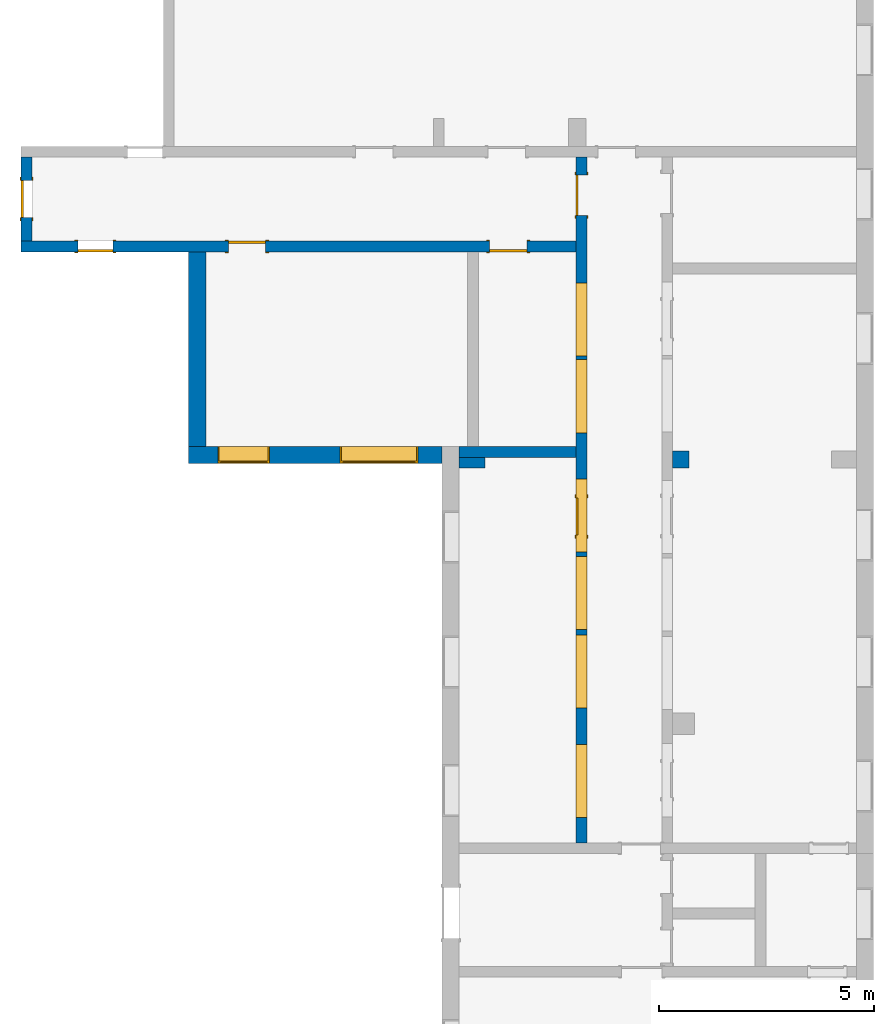
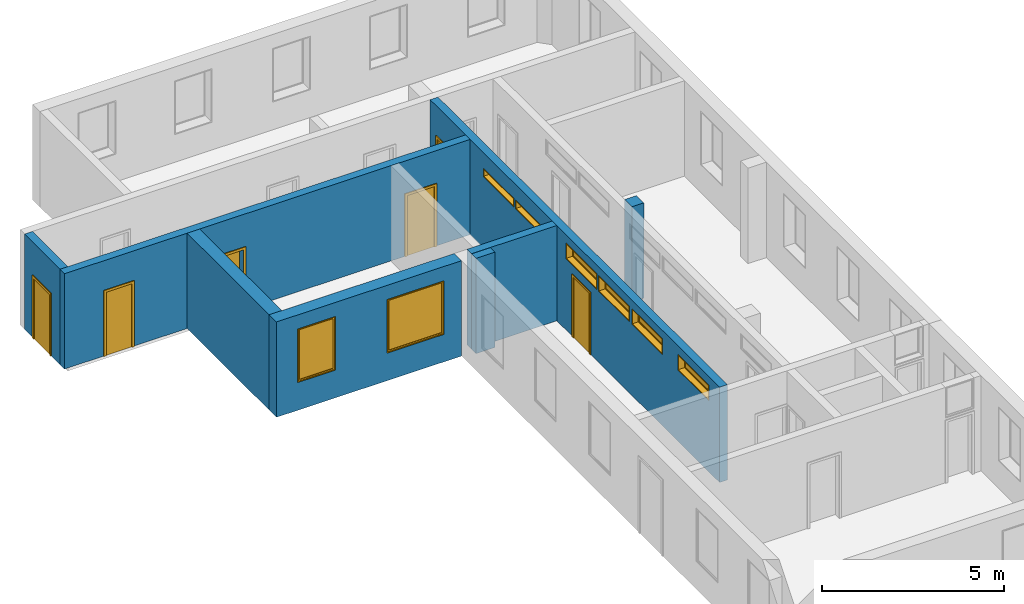
"""IFC2X3 building model written with IfcOpenShell, lengths in millimetres."""

from ifc_helpers import new_model, entity, si_unit, converted_unit, derived_unit, direction, frame, frame_2d, origin, origin_2d_with_axis, place, context, subcontext, project, spatial, polyline, rectangle, outline, extrude, source, transform, mapped, material, material_list, layer, layer_set, layer_usage, type_object, type_shapes, element, fill, save


model = new_model("IFC2X3")

# Units and contexts
model_context = context("Model", 3, precision=0.01, world=origin(), true_north=direction((6.12303176911189e-17, 1.0)))
context_of_model = context(None, 3, precision=0.01, world=origin(), true_north=direction((6.12303176911189e-17, 1.0)))
body_context = subcontext(model_context, "Body", "Model", "MODEL_VIEW")
ifc_project = project(units=[si_unit("LENGTHUNIT", "METRE", prefix="MILLI"), si_unit("AREAUNIT", "SQUARE_METRE"), si_unit("VOLUMEUNIT", "CUBIC_METRE"), converted_unit("PLANEANGLEUNIT", "DEGREE", entity("IfcRatioMeasure", 0.0174532925199433), si_unit("PLANEANGLEUNIT", "RADIAN"), dimensions=[0, 0, 0, 0, 0, 0, 0]), si_unit("MASSUNIT", "GRAM", prefix="KILO"), si_unit("TIMEUNIT", "SECOND"), si_unit("FREQUENCYUNIT", "HERTZ"), si_unit("THERMODYNAMICTEMPERATUREUNIT", "DEGREE_CELSIUS"), derived_unit("THERMALTRANSMITTANCEUNIT", [(si_unit("MASSUNIT", "GRAM", prefix="KILO"), 1), (si_unit("THERMODYNAMICTEMPERATUREUNIT", "KELVIN"), -1), (si_unit("TIMEUNIT", "SECOND"), -3)]), derived_unit("VOLUMETRICFLOWRATEUNIT", [(si_unit("LENGTHUNIT", "METRE"), 3), (si_unit("TIMEUNIT", "SECOND"), -1)]), si_unit("ELECTRICCURRENTUNIT", "AMPERE"), si_unit("ELECTRICVOLTAGEUNIT", "VOLT"), si_unit("POWERUNIT", "WATT"), si_unit("FORCEUNIT", "NEWTON", prefix="KILO"), si_unit("ILLUMINANCEUNIT", "LUX"), si_unit("LUMINOUSFLUXUNIT", "LUMEN"), si_unit("LUMINOUSINTENSITYUNIT", "CANDELA"), si_unit("PRESSUREUNIT", "PASCAL")], contexts=[model_context, context_of_model])

# Site, building, storey
site_placement = place(None, origin())
site = spatial("IfcSite", under=ifc_project, at=site_placement, CompositionType="ELEMENT")
building_placement = place(site_placement, origin())
building = spatial("IfcBuilding", under=site, at=building_placement, CompositionType="ELEMENT")
storey_1_placement = place(building_placement, origin())
storey_1 = spatial("IfcBuildingStorey", under=building, at=storey_1_placement, Name="i Plan", CompositionType="ELEMENT", Elevation=-5.41433564649196e-13)

# Wall, openings
ifc_material_1 = material(Name="Brick, Common")
ifc_layer_1 = layer(ifc_material_1, 400.0)
ifc_layer_set_1 = layer_set([ifc_layer_1], Name="Basic Wall:400mm")
ifc_layer_usage_1 = layer_usage(ifc_layer_set_1, "AXIS2", "NEGATIVE", 200.0)
wall_type_1 = type_object("IfcWallType", Name="Basic Wall:400mm", PredefinedType="STANDARD", material=ifc_layer_set_1)
wall_1_placement = place(storey_1_placement, frame((-4511.58809277855, 2433.01583504001, 0.0), z_axis=(0.0, 0.0, 1.0), x_axis=(-1.0, 0.0, 0.0)))
wall_1 = element("IfcWallStandardCase", 1, at=wall_1_placement, inside=storey_1, type_object=wall_type_1, material=ifc_layer_usage_1, Name="Basic Wall:400mm", ObjectType="Basic Wall:400mm", context=body_context, shape_type="SweptSolid", body=[
    extrude(rectangle(XDim=5876.63670242216, YDim=400.0, at=frame_2d((2938.31835121108, 2.8421709430404e-14), x_axis=(-1.0, 0.0))), origin(), (0.0, 0.0, 1.0), 3199.99999999984),
])
opening_1_placement = place(wall_1_placement, frame((4001.63670242216, -200.0, 930.0)))
opening_1 = element("IfcOpeningElement", 2, at=opening_1_placement, cuts=wall_1, Name="M_Fixed:72_1", ObjectType="Opening", context=body_context, shape_type="SweptSolid", body=[
    extrude(rectangle(XDim=1800.0, YDim=1200.0, at=frame_2d((899.999999999998, 600.000000000001), x_axis=(1.0, 0.0))), frame((0.0, 0.0, 0.0), z_axis=(0.0, 1.0, 0.0), x_axis=(0.0, 0.0, 1.0)), (0.0, 0.0, 1.0), 400.0),
])
opening_2_placement = place(wall_1_placement, frame((561.636702422159, -200.0, 922.685489525412)))
opening_2 = element("IfcOpeningElement", 3, at=opening_2_placement, cuts=wall_1, Name="M_Fixed:72_2 extra long:1", ObjectType="Opening", context=body_context, shape_type="SweptSolid", body=[
    extrude(rectangle(XDim=1800.0, YDim=1800.0, at=frame_2d((899.999999999998, 900.0), x_axis=(1.0, 0.0))), frame((0.0, 0.0, 0.0), z_axis=(0.0, 1.0, 0.0), x_axis=(0.0, 0.0, 1.0)), (0.0, 0.0, 1.0), 400.0),
])

# Storey
storey_2_placement = place(building_placement, frame((0.0, 0.0, 960.0)))
storey_2 = spatial("IfcBuildingStorey", under=building, at=storey_2_placement, Name="Bottom windows", CompositionType="ELEMENT", Elevation=959.999999999999)

# Window
ifc_material_2 = material(Name="Glass")
ifc_material_3 = material(Name="Sash")
ifc_material_list_1 = material_list([ifc_material_2, ifc_material_3])
ifc_material_list_2 = material_list([ifc_material_2, ifc_material_3])
window_style_1 = type_object("IfcWindowStyle", Name="72", ConstructionType="NOTDEFINED", OperationType="NOTDEFINED", ParameterTakesPrecedence=False, Sizeable=False, material=ifc_material_list_2)
shared_shape_1 = source(origin(), body_context, "Body", "SweptSolid", [
    extrude(rectangle(XDim=12.0, YDim=1074.0, at=origin_2d_with_axis()), frame((600.0, 359.0, 63.0), z_axis=(0.0, 0.0, 1.0), x_axis=(0.0, -1.0, 0.0)), (0.0, 0.0, 1.0), 1674.0),
    extrude(outline(polyline([(-581.0, -881.0), (581.0, -881.0), (581.0, 881.0), (-581.0, 881.0), (-581.0, -881.0)]), holes=[polyline([(-537.0, -837.0), (-537.0, 837.0), (537.0, 837.0), (537.0, -837.0), (-537.0, -837.0)])]), frame((600.0, 337.0, 900.0), z_axis=(0.0, 1.0, 0.0), x_axis=(1.0, 0.0, 0.0)), (0.0, 0.0, 1.0), 44.0000000000274),
    extrude(outline(polyline([(-600.0, -900.0), (600.0, -900.0), (600.0, 900.0), (-600.0, 900.0), (-600.0, -900.0)]), holes=[polyline([(-581.0, -881.0), (-581.0, 881.0), (581.0, 881.0), (581.0, -881.0), (-581.0, -881.0)])]), frame((600.0, 337.0, 900.0), z_axis=(0.0, 1.0, 0.0), x_axis=(1.0, 0.0, 0.0)), (0.0, 0.0, 1.0), 63.0000000000275),
    extrude(outline(polyline([(-600.0, -900.0), (600.0, -900.0), (600.0, 900.0), (-600.0, 900.0), (-600.0, -900.0)]), holes=[polyline([(-568.0, -868.0), (-568.0, 868.0), (568.0, 868.0), (568.0, -868.0), (-568.0, -868.0)])]), frame((600.0, 0.0, 900.0), z_axis=(0.0, 1.0, 0.0), x_axis=(1.0, 0.0, 0.0)), (0.0, 0.0, 1.0), 336.999999999973),
])
type_shapes(window_style_1, [shared_shape_1])
window_1_placement = place(opening_1_placement, origin())
window_1 = element("IfcWindow", 4, at=window_1_placement, inside=storey_2, type_object=window_style_1, material=ifc_material_list_1, Name="M_Fixed:72", ObjectType="72", OverallHeight=1800.0, OverallWidth=1200.0, context=body_context, shape_type="MappedRepresentation", body=[
    mapped(shared_shape_1, transform((0.0, 0.0, 0.0), scale=1.0)),
])

fill(opening_1, window_1)

ifc_material_list_3 = material_list([ifc_material_2, ifc_material_3])
ifc_material_list_4 = material_list([ifc_material_2, ifc_material_3])
window_style_2 = type_object("IfcWindowStyle", Name="72_2 extra long", ConstructionType="NOTDEFINED", OperationType="NOTDEFINED", ParameterTakesPrecedence=False, Sizeable=False, material=ifc_material_list_4)
shared_shape_2 = source(origin(), body_context, "Body", "SweptSolid", [
    extrude(rectangle(XDim=12.0, YDim=1674.0, at=origin_2d_with_axis()), frame((900.0, 359.0, 63.0), z_axis=(0.0, 0.0, 1.0), x_axis=(0.0, -1.0, 0.0)), (0.0, 0.0, 1.0), 1674.0),
    extrude(outline(polyline([(-881.0, -881.0), (881.0, -881.0), (881.0, 881.0), (-881.0, 881.0), (-881.0, -881.0)]), holes=[polyline([(-837.0, -837.0), (-837.0, 837.0), (837.0, 837.0), (837.0, -837.0), (-837.0, -837.0)])]), frame((900.0, 337.0, 900.0), z_axis=(0.0, 1.0, 0.0), x_axis=(1.0, 0.0, 0.0)), (0.0, 0.0, 1.0), 44.0000000000274),
    extrude(outline(polyline([(-900.0, -900.0), (900.0, -900.0), (900.0, 900.0), (-900.0, 900.0), (-900.0, -900.0)]), holes=[polyline([(-881.0, -881.0), (-881.0, 881.0), (881.0, 881.0), (881.0, -881.0), (-881.0, -881.0)])]), frame((900.0, 337.0, 900.0), z_axis=(0.0, 1.0, 0.0), x_axis=(1.0, 0.0, 0.0)), (0.0, 0.0, 1.0), 63.0000000000275),
    extrude(outline(polyline([(-900.0, -900.0), (900.0, -900.0), (900.0, 900.0), (-900.0, 900.0), (-900.0, -900.0)]), holes=[polyline([(-868.0, -868.0), (-868.0, 868.0), (868.0, 868.0), (868.0, -868.0), (-868.0, -868.0)])]), frame((900.0, 0.0, 900.0), z_axis=(0.0, 1.0, 0.0), x_axis=(1.0, 0.0, 0.0)), (0.0, 0.0, 1.0), 336.999999999973),
])
type_shapes(window_style_2, [shared_shape_2])
window_2_placement = place(opening_2_placement, origin())
window_2 = element("IfcWindow", 5, at=window_2_placement, inside=storey_1, type_object=window_style_2, material=ifc_material_list_3, Name="M_Fixed:72_2 extra long", ObjectType="72_2 extra long", OverallHeight=1800.0, OverallWidth=1800.0, context=body_context, shape_type="MappedRepresentation", body=[
    mapped(shared_shape_2, transform((0.0, 0.0, 0.0), scale=1.0)),
])

fill(opening_2, window_2)

# Wall
ifc_layer_usage_2 = layer_usage(ifc_layer_set_1, "AXIS2", "NEGATIVE", 200.0)
wall_2_placement = place(storey_1_placement, frame((-10188.2247952007, 2633.01583504002, 0.0), z_axis=(0.0, 0.0, 1.0), x_axis=(0.0, 1.0, 0.0)))
element("IfcWallStandardCase", 6, at=wall_2_placement, inside=storey_1, type_object=wall_type_1, material=ifc_layer_usage_2, Name="Basic Wall:400mm", ObjectType="Basic Wall:400mm", context=body_context, shape_type="SweptSolid", body=[
    extrude(rectangle(XDim=4514.61973649557, YDim=400.0, at=frame_2d((2257.30986824779, 3.41060513164848e-13), x_axis=(-1.0, 0.0))), origin(), (0.0, 0.0, 1.0), 3199.99999999984),
])

# Wall, openings, doors
ifc_material_4 = material(Name="Default Wall")
ifc_layer_2 = layer(ifc_material_4, 250.0)
ifc_layer_set_2 = layer_set([ifc_layer_2], Name="Basic Wall:250 mm")
ifc_layer_usage_3 = layer_usage(ifc_layer_set_2, "AXIS2", "NEGATIVE", 125.0)
wall_type_2 = type_object("IfcWallType", Name="Basic Wall:250 mm", PredefinedType="STANDARD", material=ifc_layer_set_2)
wall_3_placement = place(storey_1_placement, frame((-1401.58809277854, 7272.63557153557, 0.0), z_axis=(0.0, 0.0, 1.0), x_axis=(-1.0, 0.0, 0.0)))
wall_3 = element("IfcWallStandardCase", 7, at=wall_3_placement, inside=storey_1, type_object=wall_type_2, material=ifc_layer_usage_3, Name="Basic Wall:250 mm", ObjectType="Basic Wall:250 mm", context=body_context, shape_type="SweptSolid", body=[
    extrude(rectangle(XDim=12876.3718701131, YDim=249.999999999999, at=frame_2d((6438.18593505655, -5.6843418860808e-14), x_axis=(-1.0, 0.0))), origin(), (0.0, 0.0, 1.0), 3199.99999999984),
])
opening_3_placement = place(wall_3_placement, frame((1142.63670242217, -125.0, 0.0)))
opening_3 = element("IfcOpeningElement", 8, at=opening_3_placement, cuts=wall_3, Name="M_Single-Flush:0864 x 2032mm:1", ObjectType="Opening", context=body_context, shape_type="SweptSolid", body=[
    extrude(rectangle(XDim=863.999999999999, YDim=2032.0, at=frame_2d((1016.0, 432.0), x_axis=(0.0, 1.0))), frame((0.0, 0.0, 0.0), z_axis=(0.0, 1.0, 0.0), x_axis=(0.0, 0.0, 1.0)), (0.0, 0.0, 1.0), 250.0),
])
opening_4_placement = place(wall_3_placement, frame((8066.63670242217, 125.0, 0.0)))
opening_4 = element("IfcOpeningElement", 9, at=opening_4_placement, cuts=wall_3, Name="M_Single-Flush:0864 x 2032mm:1", ObjectType="Opening", context=body_context, shape_type="SweptSolid", body=[
    extrude(rectangle(XDim=863.999999999999, YDim=2032.0, at=frame_2d((1016.0, 432.0), x_axis=(0.0, 1.0))), frame((0.0, 0.0, 0.0), z_axis=(0.0, -1.0, 0.0), x_axis=(0.0, 0.0, 1.0)), (0.0, 0.0, 1.0), 250.0),
])
opening_5_placement = place(wall_3_placement, frame((10747.7701846591, -125.0, 0.0)))
opening_5 = element("IfcOpeningElement", 10, at=opening_5_placement, cuts=wall_3, Name="M_Single-Flush:0813 x 2134mm:1", ObjectType="Opening", context=body_context, shape_type="SweptSolid", body=[
    extrude(rectangle(XDim=813.0, YDim=2134.0, at=frame_2d((1067.0, 406.5), x_axis=(0.0, 1.0))), frame((0.0, 0.0, 0.0), z_axis=(0.0, 1.0, 0.0), x_axis=(0.0, 0.0, 1.0)), (0.0, 0.0, 1.0), 250.0),
])
ifc_material_5 = material(Name="Door - Frame")
ifc_material_6 = material(Name="Door - Panel")
ifc_material_list_5 = material_list([ifc_material_5, ifc_material_6])
ifc_material_list_6 = material_list([ifc_material_5, ifc_material_6])
door_style_1 = type_object("IfcDoorStyle", Name="0813 x 2134mm", ConstructionType="NOTDEFINED", OperationType="SINGLE_SWING_RIGHT", ParameterTakesPrecedence=False, Sizeable=False, material=ifc_material_list_6)
shared_shape_3 = source(origin(), body_context, "Body", "SweptSolid", [
    extrude(outline(polyline([(-482.5, -1124.0), (482.5, -1124.0), (482.5, 1086.0), (406.5, 1086.0), (406.5, -1048.0), (-406.5, -1048.0), (-406.5, 1086.0), (-482.5, 1086.0), (-482.5, -1124.0)])), frame((406.500000000001, 250.0, 1086.0), z_axis=(0.0, 1.0, 0.0), x_axis=(1.0, 0.0, 0.0)), (0.0, 0.0, 1.0), 24.9999999999945),
    extrude(outline(polyline([(-1124.0, -482.499999999997), (1086.0, -482.499999999997), (1086.0, -406.500000000007), (-1048.0, -406.500000000007), (-1048.0, 406.500000000002), (1086.0, 406.500000000002), (1086.0, 482.500000000003), (-1124.0, 482.500000000003), (-1124.0, -482.499999999997)])), frame((406.500000000003, -25.0, 1086.0), z_axis=(0.0, 1.0, 0.0), x_axis=(0.0, 0.0, -1.0)), (0.0, 0.0, 1.0), 25.0000000000056),
    extrude(rectangle(XDim=51.0, YDim=813.0, at=frame_2d((5.32907051820075e-15, 0.0), x_axis=(1.0, 0.0))), frame((406.5, 224.499999999999, 0.0), z_axis=(0.0, 0.0, 1.0), x_axis=(0.0, 1.0, 0.0)), (0.0, 0.0, 1.0), 2134.0),
])
type_shapes(door_style_1, [shared_shape_3])
door_1_placement = place(opening_5_placement, origin())
door_1 = element("IfcDoor", 11, at=door_1_placement, inside=storey_1, type_object=door_style_1, material=ifc_material_list_5, Name="M_Single-Flush:0813 x 2134mm", ObjectType="0813 x 2134mm", OverallHeight=2134.0, OverallWidth=812.999999999999, context=body_context, shape_type="MappedRepresentation", body=[
    mapped(shared_shape_3, transform((0.0, 0.0, 0.0), scale=1.0)),
])
fill(opening_5, door_1)
ifc_material_list_7 = material_list([ifc_material_5, ifc_material_6])
ifc_material_list_8 = material_list([ifc_material_5, ifc_material_6])
door_style_2 = type_object("IfcDoorStyle", Name="0864 x 2032mm", ConstructionType="NOTDEFINED", OperationType="SINGLE_SWING_RIGHT", ParameterTakesPrecedence=False, Sizeable=False, material=ifc_material_list_8)
shared_shape_4 = source(origin(), body_context, "Body", "SweptSolid", [
    extrude(outline(polyline([(-508.0, -1073.0), (508.0, -1073.0), (508.0, 1035.0), (432.0, 1035.0), (432.0, -997.0), (-432.0, -997.0), (-432.0, 1035.0), (-508.0, 1035.0), (-508.0, -1073.0)])), frame((432.0, 250.0, 1035.0), z_axis=(0.0, 1.0, 0.0), x_axis=(1.0, 0.0, 0.0)), (0.0, 0.0, 1.0), 24.9999999999945),
    extrude(outline(polyline([(-1073.0, -508.0), (1035.0, -508.0), (1035.0, -432.0), (-997.0, -432.0), (-997.0, 432.0), (1035.0, 432.0), (1035.0, 508.0), (-1073.0, 508.0), (-1073.0, -508.0)])), frame((432.0, -25.0, 1035.0), z_axis=(0.0, 1.0, 0.0), x_axis=(0.0, 0.0, -1.0)), (0.0, 0.0, 1.0), 25.0000000000056),
    extrude(rectangle(XDim=51.0, YDim=864.0, at=frame_2d((5.32907051820075e-15, 0.0), x_axis=(1.0, 0.0))), frame((432.0, 224.499999999999, 0.0), z_axis=(0.0, 0.0, 1.0), x_axis=(0.0, 1.0, 0.0)), (0.0, 0.0, 1.0), 2032.0),
])
type_shapes(door_style_2, [shared_shape_4])
door_2_placement = place(opening_3_placement, origin())
door_2 = element("IfcDoor", 12, at=door_2_placement, inside=storey_1, type_object=door_style_2, material=ifc_material_list_7, Name="M_Single-Flush:0864 x 2032mm", ObjectType="0864 x 2032mm", OverallHeight=2032.0, OverallWidth=864.0, context=body_context, shape_type="MappedRepresentation", body=[
    mapped(shared_shape_4, transform((0.0, 0.0, 0.0), scale=1.0)),
])
fill(opening_3, door_2)
ifc_material_list_9 = material_list([ifc_material_5, ifc_material_6])
door_3_placement = place(opening_4_placement, frame((0.0, 0.0, 0.0), z_axis=(0.0, 0.0, 1.0), x_axis=(-1.0, 0.0, 0.0)))
door_3 = element("IfcDoor", 13, at=door_3_placement, inside=storey_1, type_object=door_style_2, material=ifc_material_list_9, Name="M_Single-Flush:0864 x 2032mm", ObjectType="0864 x 2032mm", OverallHeight=2032.0, OverallWidth=864.0, context=body_context, shape_type="MappedRepresentation", body=[
    mapped(shared_shape_4, transform((0.0, 0.0, 0.0), scale=1.0)),
])
fill(opening_4, door_3)

# Wall, opening, door
ifc_layer_usage_4 = layer_usage(ifc_layer_set_2, "AXIS2", "NEGATIVE", 125.0)
wall_4_placement = place(storey_1_placement, frame((-14152.9599628916, 7397.63557153561, 0.0), z_axis=(0.0, 0.0, 1.0), x_axis=(0.0, 1.0, 0.0)))
wall_4 = element("IfcWallStandardCase", 14, at=wall_4_placement, inside=storey_1, type_object=wall_type_2, material=ifc_layer_usage_4, Name="Basic Wall:250 mm", ObjectType="Basic Wall:250 mm", context=body_context, shape_type="SweptSolid", body=[
    extrude(rectangle(XDim=1949.17317172519, YDim=249.999999999999, at=frame_2d((974.586585862593, -1.49213974509621e-13), x_axis=(-1.0, 0.0))), origin(), (0.0, 0.0, 1.0), 3199.99999999984),
])
opening_6_placement = place(wall_4_placement, frame((545.173171725184, -125.0, 0.0)))
opening_6 = element("IfcOpeningElement", 15, at=opening_6_placement, cuts=wall_4, Name="M_Single-Flush:0864 x 2032mm:1", ObjectType="Opening", context=body_context, shape_type="SweptSolid", body=[
    extrude(rectangle(XDim=863.999999999999, YDim=2032.0, at=frame_2d((1016.0, 432.0), x_axis=(0.0, 1.0))), frame((0.0, 0.0, 0.0), z_axis=(0.0, 1.0, 0.0), x_axis=(0.0, 0.0, 1.0)), (0.0, 0.0, 1.0), 250.0),
])
ifc_material_list_10 = material_list([ifc_material_5, ifc_material_6])
door_4_placement = place(opening_6_placement, origin())
door_4 = element("IfcDoor", 16, at=door_4_placement, inside=storey_1, type_object=door_style_2, material=ifc_material_list_10, Name="M_Single-Flush:0864 x 2032mm", ObjectType="0864 x 2032mm", OverallHeight=2032.0, OverallWidth=864.0, context=body_context, shape_type="MappedRepresentation", body=[
    mapped(shared_shape_4, transform((0.0, 0.0, 0.0), scale=1.0)),
])
fill(opening_6, door_4)

# Wall, openings, doors, windows
ifc_layer_usage_5 = layer_usage(ifc_layer_set_2, "AXIS2", "NEGATIVE", 125.0)
wall_5_placement = place(storey_1_placement, frame((-1276.58809277854, 9346.80874326076, 0.0), z_axis=(0.0, 0.0, 1.0), x_axis=(0.0, -1.0, 0.0)))
wall_5 = element("IfcWallStandardCase", 17, at=wall_5_placement, inside=storey_1, type_object=wall_type_2, material=ifc_layer_usage_5, Name="Basic Wall:250 mm", ObjectType="Basic Wall:250 mm", context=body_context, shape_type="SweptSolid", body=[
    extrude(rectangle(XDim=15909.905039277, YDim=250.0, at=frame_2d((7954.95251963848, -2.8421709430404e-14), x_axis=(-1.0, 0.0))), origin(), (0.0, 0.0, 1.0), 3199.99999999984),
])
opening_7_placement = place(wall_5_placement, frame((8767.79290822076, 125.0, 0.0)))
opening_7 = element("IfcOpeningElement", 18, at=opening_7_placement, cuts=wall_5, Name="M_Single-Flush:0864 x 2032mm:1", ObjectType="Opening", context=body_context, shape_type="SweptSolid", body=[
    extrude(rectangle(XDim=863.999999999999, YDim=2032.0, at=frame_2d((1016.0, 432.0), x_axis=(0.0, 1.0))), frame((0.0, 0.0, 0.0), z_axis=(0.0, -1.0, 0.0), x_axis=(0.0, 0.0, 1.0)), (0.0, 0.0, 1.0), 250.0),
])
opening_8_placement = place(wall_5_placement, frame((1350.0, 125.0, 0.0)))
opening_8 = element("IfcOpeningElement", 19, at=opening_8_placement, cuts=wall_5, Name="M_Single-Flush:72 door wide:1", ObjectType="Opening", context=body_context, shape_type="SweptSolid", body=[
    extrude(rectangle(XDim=930.0, YDim=2134.0, at=frame_2d((1067.0, 465.0), x_axis=(0.0, 1.0))), frame((0.0, 0.0, 0.0), z_axis=(0.0, -1.0, 0.0), x_axis=(0.0, 0.0, 1.0)), (0.0, 0.0, 1.0), 250.0),
])
opening_9_placement = place(wall_5_placement, frame((2919.17317172519, -125.0, 2390.0)))
opening_9 = element("IfcOpeningElement", 20, at=opening_9_placement, cuts=wall_5, Name="M_Fixed:lav:1", ObjectType="Opening", context=body_context, shape_type="SweptSolid", body=[
    extrude(rectangle(XDim=289.999999999998, YDim=1700.0, at=frame_2d((144.999999999999, 850.0), x_axis=(1.0, 0.0))), frame((0.0, 0.0, 0.0), z_axis=(0.0, 1.0, 0.0), x_axis=(0.0, 0.0, 1.0)), (0.0, 0.0, 1.0), 250.0),
])
opening_10_placement = place(wall_5_placement, frame((4699.17317172519, -125.0, 2390.0)))
opening_10 = element("IfcOpeningElement", 21, at=opening_10_placement, cuts=wall_5, Name="M_Fixed:lav:1", ObjectType="Opening", context=body_context, shape_type="SweptSolid", body=[
    extrude(rectangle(XDim=289.999999999998, YDim=1700.0, at=frame_2d((144.999999999999, 850.0), x_axis=(1.0, 0.0))), frame((0.0, 0.0, 0.0), z_axis=(0.0, 1.0, 0.0), x_axis=(0.0, 0.0, 1.0)), (0.0, 0.0, 1.0), 250.0),
])
opening_11_placement = place(wall_5_placement, frame((7464.17317172518, -125.0, 2390.0)))
opening_11 = element("IfcOpeningElement", 22, at=opening_11_placement, cuts=wall_5, Name="M_Fixed:1", ObjectType="Opening", context=body_context, shape_type="SweptSolid", body=[
    extrude(rectangle(XDim=529.999999999998, YDim=1700.0, at=frame_2d((264.999999999999, 850.0), x_axis=(1.0, 0.0))), frame((0.0, 0.0, 0.0), z_axis=(0.0, 1.0, 0.0), x_axis=(0.0, 0.0, 1.0)), (0.0, 0.0, 1.0), 250.0),
])
opening_12_placement = place(wall_5_placement, frame((9264.17317172518, -125.0, 2390.0)))
opening_12 = element("IfcOpeningElement", 23, at=opening_12_placement, cuts=wall_5, Name="M_Fixed:1", ObjectType="Opening", context=body_context, shape_type="SweptSolid", body=[
    extrude(rectangle(XDim=529.999999999998, YDim=1700.0, at=frame_2d((264.999999999999, 850.0), x_axis=(1.0, 0.0))), frame((0.0, 0.0, 0.0), z_axis=(0.0, 1.0, 0.0), x_axis=(0.0, 0.0, 1.0)), (0.0, 0.0, 1.0), 250.0),
])
opening_13_placement = place(wall_5_placement, frame((11084.1731717252, -125.0, 2390.0)))
opening_13 = element("IfcOpeningElement", 24, at=opening_13_placement, cuts=wall_5, Name="M_Fixed:1", ObjectType="Opening", context=body_context, shape_type="SweptSolid", body=[
    extrude(rectangle(XDim=529.999999999998, YDim=1700.0, at=frame_2d((264.999999999999, 850.0), x_axis=(1.0, 0.0))), frame((0.0, 0.0, 0.0), z_axis=(0.0, 1.0, 0.0), x_axis=(0.0, 0.0, 1.0)), (0.0, 0.0, 1.0), 250.0),
])
opening_14_placement = place(wall_5_placement, frame((13624.1731717252, -125.0, 2390.0)))
opening_14 = element("IfcOpeningElement", 25, at=opening_14_placement, cuts=wall_5, Name="M_Fixed:1", ObjectType="Opening", context=body_context, shape_type="SweptSolid", body=[
    extrude(rectangle(XDim=529.999999999998, YDim=1700.0, at=frame_2d((264.999999999999, 850.0), x_axis=(1.0, 0.0))), frame((0.0, 0.0, 0.0), z_axis=(0.0, 1.0, 0.0), x_axis=(0.0, 0.0, 1.0)), (0.0, 0.0, 1.0), 250.0),
])
ifc_material_list_11 = material_list([ifc_material_5, ifc_material_6])
ifc_material_list_12 = material_list([ifc_material_5, ifc_material_6])
door_style_3 = type_object("IfcDoorStyle", Name="72 door wide", ConstructionType="NOTDEFINED", OperationType="SINGLE_SWING_RIGHT", ParameterTakesPrecedence=False, Sizeable=False, material=ifc_material_list_12)
shared_shape_5 = source(origin(), body_context, "Body", "SweptSolid", [
    extrude(outline(polyline([(-541.0, -1124.0), (541.0, -1124.0), (541.0, 1086.0), (465.0, 1086.0), (465.0, -1048.0), (-465.0, -1048.0), (-465.0, 1086.0), (-541.0, 1086.0), (-541.0, -1124.0)])), frame((465.0, 250.0, 1086.0), z_axis=(0.0, 1.0, 0.0), x_axis=(1.0, 0.0, 0.0)), (0.0, 0.0, 1.0), 24.9999999999945),
    extrude(outline(polyline([(-1124.0, -541.0), (1086.0, -541.0), (1086.0, -465.0), (-1048.0, -465.0), (-1048.0, 465.0), (1086.0, 465.0), (1086.0, 541.0), (-1124.0, 541.0), (-1124.0, -541.0)])), frame((465.0, -25.0, 1086.0), z_axis=(0.0, 1.0, 0.0), x_axis=(0.0, 0.0, -1.0)), (0.0, 0.0, 1.0), 25.0000000000056),
    extrude(rectangle(XDim=51.0, YDim=930.0, at=frame_2d((5.32907051820075e-15, 0.0), x_axis=(1.0, 0.0))), frame((465.0, 224.499999999999, 0.0), z_axis=(0.0, 0.0, 1.0), x_axis=(0.0, 1.0, 0.0)), (0.0, 0.0, 1.0), 2134.0),
])
type_shapes(door_style_3, [shared_shape_5])
door_5_placement = place(opening_8_placement, frame((0.0, 0.0, 0.0), z_axis=(0.0, 0.0, 1.0), x_axis=(-1.0, 0.0, 0.0)))
door_5 = element("IfcDoor", 26, at=door_5_placement, inside=storey_1, type_object=door_style_3, material=ifc_material_list_11, Name="M_Single-Flush:72 door wide", ObjectType="72 door wide", OverallHeight=2134.0, OverallWidth=930.0, context=body_context, shape_type="MappedRepresentation", body=[
    mapped(shared_shape_5, transform((0.0, 0.0, 0.0), scale=1.0)),
])
fill(opening_8, door_5)
ifc_material_list_13 = material_list([ifc_material_5, ifc_material_6])
door_6_placement = place(opening_7_placement, frame((0.0, 0.0, 0.0), z_axis=(0.0, 0.0, 1.0), x_axis=(-1.0, 0.0, 0.0)))
door_6 = element("IfcDoor", 27, at=door_6_placement, inside=storey_1, type_object=door_style_2, material=ifc_material_list_13, Name="M_Single-Flush:0864 x 2032mm", ObjectType="0864 x 2032mm", OverallHeight=2032.0, OverallWidth=864.0, context=body_context, shape_type="MappedRepresentation", body=[
    mapped(shared_shape_4, transform((0.0, 0.0, 0.0), scale=1.0)),
])
fill(opening_7, door_6)
ifc_material_list_14 = material_list([ifc_material_2, ifc_material_3])
ifc_material_list_15 = material_list([ifc_material_2, ifc_material_3])
window_style_3 = type_object("IfcWindowStyle", ConstructionType="NOTDEFINED", OperationType="NOTDEFINED", ParameterTakesPrecedence=False, Sizeable=False, material=ifc_material_list_15)
shared_shape_6 = source(origin(), body_context, "Body", "SweptSolid", [
    extrude(rectangle(XDim=1574.0, YDim=12.0, at=frame_2d((0.0, -8.43769498715119e-15), x_axis=(1.0, 0.0))), frame((850.0, 235.0, 63.0), z_axis=(0.0, 0.0, 1.0), x_axis=(-1.0, 0.0, 0.0)), (0.0, 0.0, 1.0), 404.000000000007),
    extrude(outline(polyline([(-831.0, -246.0), (831.0, -246.0), (831.0, 246.0), (-831.0, 246.0), (-831.0, -246.0)]), holes=[polyline([(-787.0, -202.0), (-787.0, 202.0), (787.0, 202.0), (787.0, -202.0), (-787.0, -202.0)])]), frame((850.0, 257.0, 265.0), z_axis=(0.0, -1.0, 0.0), x_axis=(-1.0, 0.0, 0.0)), (0.0, 0.0, 1.0), 44.0000000000274),
    extrude(outline(polyline([(-850.0, -265.0), (850.0, -265.0), (850.0, 265.0), (-850.0, 265.0), (-850.0, -265.0)]), holes=[polyline([(-831.0, -246.0), (-831.0, 246.0), (831.0, 246.0), (831.0, -246.0), (-831.0, -246.0)])]), frame((850.0, 276.0, 265.0), z_axis=(0.0, -1.0, 0.0), x_axis=(-1.0, 0.0, 0.0)), (0.0, 0.0, 1.0), 63.0000000000274),
    extrude(outline(polyline([(-850.0, -265.0), (850.0, -265.0), (850.0, 265.0), (-850.0, 265.0), (-850.0, -265.0)]), holes=[polyline([(-818.0, -233.0), (-818.0, 233.0), (818.0, 233.0), (818.0, -233.0), (-818.0, -233.0)])]), frame((850.0, 213.0, 265.0), z_axis=(0.0, -1.0, 0.0), x_axis=(-1.0, 0.0, 0.0)), (0.0, 0.0, 1.0), 186.999999999973),
])
type_shapes(window_style_3, [shared_shape_6])
window_3_placement = place(opening_11_placement, frame((0.0, -26.0, 0.0)))
window_3 = element("IfcWindow", 28, at=window_3_placement, inside=storey_2, type_object=window_style_3, material=ifc_material_list_14, Name="M_Fixed", OverallHeight=529.999999999998, OverallWidth=1700.0, context=body_context, shape_type="MappedRepresentation", body=[
    mapped(shared_shape_6, transform((0.0, 0.0, 0.0), scale=1.0)),
])
fill(opening_11, window_3)
ifc_material_list_16 = material_list([ifc_material_2, ifc_material_3])
window_4_placement = place(opening_12_placement, frame((0.0, -26.0, 0.0)))
window_4 = element("IfcWindow", 29, at=window_4_placement, inside=storey_2, type_object=window_style_3, material=ifc_material_list_16, Name="M_Fixed", OverallHeight=529.999999999998, OverallWidth=1700.0, context=body_context, shape_type="MappedRepresentation", body=[
    mapped(shared_shape_6, transform((0.0, 0.0, 0.0), scale=1.0)),
])
fill(opening_12, window_4)
ifc_material_list_17 = material_list([ifc_material_2, ifc_material_3])
window_5_placement = place(opening_13_placement, frame((0.0, -26.0, 0.0)))
window_5 = element("IfcWindow", 30, at=window_5_placement, inside=storey_2, type_object=window_style_3, material=ifc_material_list_17, Name="M_Fixed", OverallHeight=529.999999999998, OverallWidth=1700.0, context=body_context, shape_type="MappedRepresentation", body=[
    mapped(shared_shape_6, transform((0.0, 0.0, 0.0), scale=1.0)),
])
fill(opening_13, window_5)
ifc_material_list_18 = material_list([ifc_material_2, ifc_material_3])
window_6_placement = place(opening_14_placement, frame((0.0, -26.0, 0.0)))
window_6 = element("IfcWindow", 31, at=window_6_placement, inside=storey_2, type_object=window_style_3, material=ifc_material_list_18, Name="M_Fixed", OverallHeight=529.999999999998, OverallWidth=1700.0, context=body_context, shape_type="MappedRepresentation", body=[
    mapped(shared_shape_6, transform((0.0, 0.0, 0.0), scale=1.0)),
])
fill(opening_14, window_6)
ifc_material_list_19 = material_list([ifc_material_2, ifc_material_3])
ifc_material_list_20 = material_list([ifc_material_2, ifc_material_3])
window_style_4 = type_object("IfcWindowStyle", Name="lav", ConstructionType="NOTDEFINED", OperationType="NOTDEFINED", ParameterTakesPrecedence=False, Sizeable=False, material=ifc_material_list_20)
shared_shape_7 = source(origin(), body_context, "Body", "SweptSolid", [
    extrude(rectangle(XDim=1574.0, YDim=12.0, at=frame_2d((0.0, -8.43769498715119e-15), x_axis=(1.0, 0.0))), frame((850.0, 235.0, 63.0), z_axis=(0.0, 0.0, 1.0), x_axis=(-1.0, 0.0, 0.0)), (0.0, 0.0, 1.0), 164.000000000007),
    extrude(outline(polyline([(-831.0, -126.0), (831.0, -126.0), (831.0, 126.0), (-831.0, 126.0), (-831.0, -126.0)]), holes=[polyline([(-787.0, -82.0), (-787.0, 82.0), (787.0, 82.0), (787.0, -82.0), (-787.0, -82.0)])]), frame((850.0, 257.0, 145.0), z_axis=(0.0, -1.0, 0.0), x_axis=(-1.0, 0.0, 0.0)), (0.0, 0.0, 1.0), 44.0000000000274),
    extrude(outline(polyline([(-850.0, -145.0), (850.0, -145.0), (850.0, 145.0), (-850.0, 145.0), (-850.0, -145.0)]), holes=[polyline([(-831.0, -126.0), (-831.0, 126.0), (831.0, 126.0), (831.0, -126.0), (-831.0, -126.0)])]), frame((850.0, 276.0, 145.0), z_axis=(0.0, -1.0, 0.0), x_axis=(-1.0, 0.0, 0.0)), (0.0, 0.0, 1.0), 63.0000000000274),
    extrude(outline(polyline([(-850.0, -145.0), (850.0, -145.0), (850.0, 145.0), (-850.0, 145.0), (-850.0, -145.0)]), holes=[polyline([(-818.0, -113.0), (-818.0, 113.0), (818.0, 113.0), (818.0, -113.0), (-818.0, -113.0)])]), frame((850.0, 213.0, 145.0), z_axis=(0.0, -1.0, 0.0), x_axis=(-1.0, 0.0, 0.0)), (0.0, 0.0, 1.0), 186.999999999973),
])
type_shapes(window_style_4, [shared_shape_7])
window_7_placement = place(opening_9_placement, frame((0.0, -26.0, 0.0)))
window_7 = element("IfcWindow", 32, at=window_7_placement, inside=storey_2, type_object=window_style_4, material=ifc_material_list_19, Name="M_Fixed:lav", ObjectType="lav", OverallHeight=289.999999999999, OverallWidth=1700.0, context=body_context, shape_type="MappedRepresentation", body=[
    mapped(shared_shape_7, transform((0.0, 0.0, 0.0), scale=1.0)),
])
fill(opening_9, window_7)
ifc_material_list_21 = material_list([ifc_material_2, ifc_material_3])
window_8_placement = place(opening_10_placement, frame((0.0, -26.0, 0.0)))
window_8 = element("IfcWindow", 33, at=window_8_placement, inside=storey_2, type_object=window_style_4, material=ifc_material_list_21, Name="M_Fixed:lav", ObjectType="lav", OverallHeight=289.999999999999, OverallWidth=1700.0, context=body_context, shape_type="MappedRepresentation", body=[
    mapped(shared_shape_7, transform((0.0, 0.0, 0.0), scale=1.0)),
])
fill(opening_10, window_8)

# Walls
ifc_layer_usage_6 = layer_usage(ifc_layer_set_2, "AXIS2", "NEGATIVE", 125.0)
wall_6_placement = place(storey_1_placement, frame((-4111.58809277855, 2508.01583504, 0.0)))
element("IfcWallStandardCase", 34, at=wall_6_placement, inside=storey_1, type_object=wall_type_2, material=ifc_layer_usage_6, Name="Basic Wall:250 mm", ObjectType="Basic Wall:250 mm", context=body_context, shape_type="SweptSolid", body=[
    extrude(rectangle(XDim=2710.0, YDim=250.0, at=frame_2d((1355.0, -6.3948846218409e-14), x_axis=(-1.0, 0.0))), origin(), (0.0, 0.0, 1.0), 3199.99999999984),
])
ifc_layer_3 = layer(ifc_material_4, 400.0)
ifc_layer_set_3 = layer_set([ifc_layer_3], Name="Basic Wall:400mm 2")
ifc_layer_usage_7 = layer_usage(ifc_layer_set_3, "AXIS2", "NEGATIVE", 200.0)
wall_type_3 = type_object("IfcWallType", Name="Basic Wall:400mm 2", PredefinedType="STANDARD", material=ifc_layer_set_3)
wall_7_placement = place(storey_1_placement, frame((838.411907221449, 2330.33872415507, 0.0)))
element("IfcWallStandardCase", 35, at=wall_7_placement, inside=storey_1, type_object=wall_type_3, material=ifc_layer_usage_7, Name="Basic Wall:400mm 2", ObjectType="Basic Wall:400mm 2", context=body_context, shape_type="SweptSolid", body=[
    extrude(rectangle(XDim=375.0, YDim=400.0, at=frame_2d((187.5, -4.2632564145606e-14), x_axis=(-1.0, 0.0))), origin(), (0.0, 0.0, 1.0), 3199.99999999984),
])
ifc_layer_4 = layer(ifc_material_4, 250.0)
ifc_layer_set_4 = layer_set([ifc_layer_4], Name="Basic Wall")
ifc_layer_usage_8 = layer_usage(ifc_layer_set_4, "AXIS2", "NEGATIVE", 125.0)
wall_type_4 = type_object("IfcWallType", Name="Basic Wall", PredefinedType="STANDARD", material=ifc_layer_set_4)
wall_8_placement = place(storey_1_placement, frame((-4111.58809277855, 2255.33872415508, 0.0)))
element("IfcWallStandardCase", 36, at=wall_8_placement, inside=storey_1, type_object=wall_type_4, material=ifc_layer_usage_8, Name="Basic Wall", ObjectType="Basic Wall", context=body_context, shape_type="SweptSolid", body=[
    extrude(rectangle(XDim=598.683438301429, YDim=250.0, at=frame_2d((299.341719150714, 0.0), x_axis=(-1.0, 0.0))), origin(), (0.0, 0.0, 1.0), 3199.99999999984),
])

save(model, "model.ifc")
